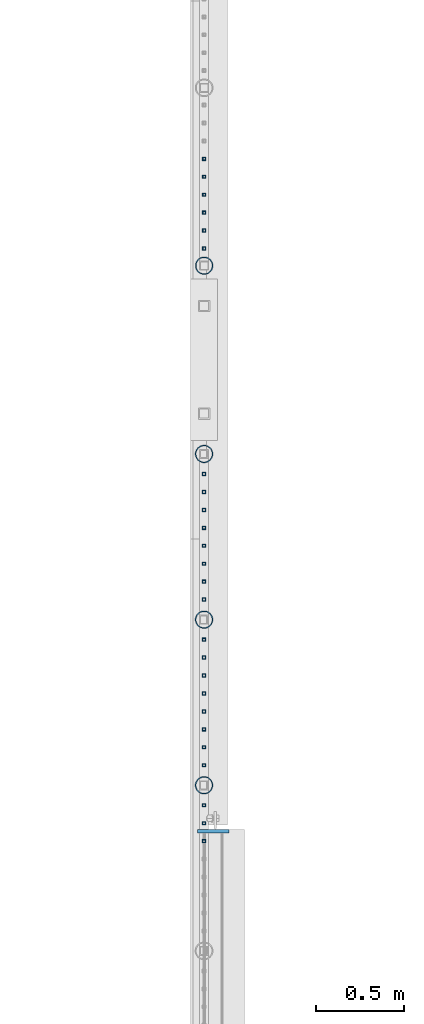
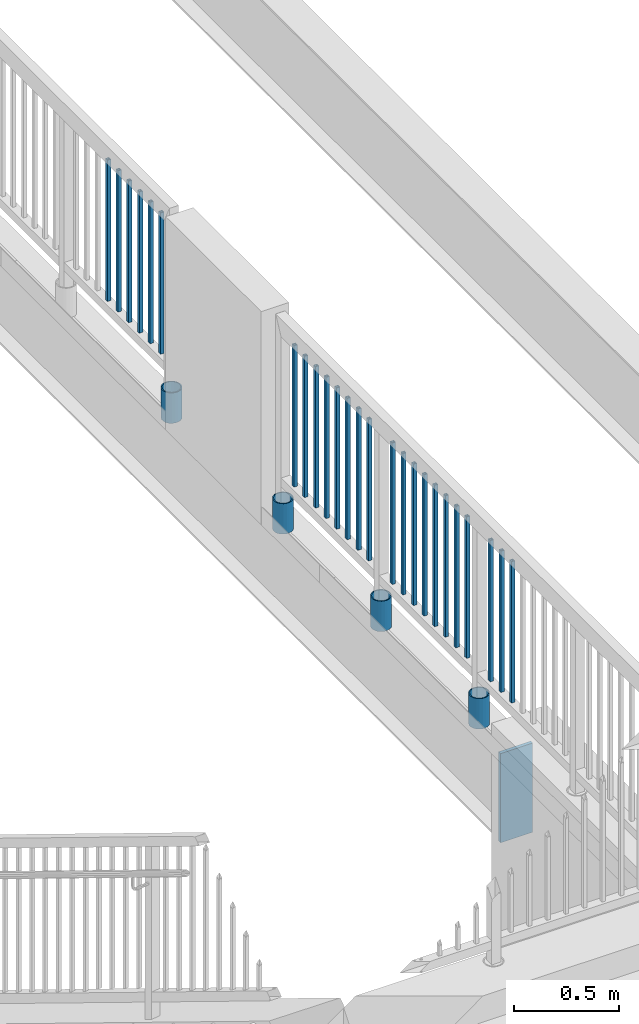
# One storey, part 227 of 975: 30 columns.
"""IFC2X3 building model written with IfcOpenShell, lengths in millimetres."""

from ifc_helpers import new_model, si_unit, frame, origin_with_axes, place, context, subcontext, project, spatial, faceted_brep, material, type_object, element, save


model = new_model("IFC2X3")

# Units and contexts
model_context = context("Model", 3, precision=1e-05, world=origin_with_axes())
body_context = subcontext(model_context, "Body", "Model", "MODEL_VIEW")
ifc_project = project(units=[si_unit("LENGTHUNIT", "METRE", prefix="MILLI"), si_unit("AREAUNIT", "SQUARE_METRE"), si_unit("VOLUMEUNIT", "CUBIC_METRE"), si_unit("MASSUNIT", "GRAM", prefix="KILO"), si_unit("TIMEUNIT", "SECOND"), si_unit("PLANEANGLEUNIT", "RADIAN"), si_unit("SOLIDANGLEUNIT", "STERADIAN"), si_unit("THERMODYNAMICTEMPERATUREUNIT", "DEGREE_CELSIUS"), si_unit("LUMINOUSINTENSITYUNIT", "LUMEN")], contexts=[model_context])

# Site, building, storey
site_placement = place(None, origin_with_axes())
site = spatial("IfcSite", under=ifc_project, at=site_placement, CompositionType="ELEMENT")
building_placement = place(site_placement, origin_with_axes())
building = spatial("IfcBuilding", under=site, at=building_placement, Name="Undefined", CompositionType="ELEMENT")
storey_placement = place(building_placement, origin_with_axes())
storey = spatial("IfcBuildingStorey", under=building, at=storey_placement, Name="Undefined", CompositionType="ELEMENT", Elevation=0.0)

# Columns
ifc_material_1 = material()
column_type_1 = type_object("IfcColumnType", Name="HSS3/4X3/4X.120_TUBES", PredefinedType="NOTDEFINED")
for number, where, z_axis, x_axis, name in (
    (1, (2092.26449887526, 26097.4441986005, 4254.49995104806), (0.0, 1.0, 0.0), (0.0, 0.0, 1.0), "PICKET"),
    (2, (2092.26449887526, 25995.8441986005, 4254.49995104806), (0.0, 1.0, 0.0), (0.0, 0.0, 1.0), "PICKET"),
    (3, (2092.26449887526, 25894.2441986005, 4254.49995104806), (0.0, 1.0, 0.0), (0.0, 0.0, 1.0), "PICKET"),
    (4, (2092.26449887526, 25792.6441986005, 4254.49995104806), (0.0, 1.0, 0.0), (0.0, 0.0, 1.0), "PICKET"),
    (5, (2092.26449887526, 25691.0441986005, 4254.49995104806), (0.0, 1.0, 0.0), (0.0, 0.0, 1.0), "PICKET"),
    (6, (2092.26449887526, 25589.4441986005, 4254.49995104806), (0.0, 1.0, 0.0), (0.0, 0.0, 1.0), "PICKET"),
    (7, (2091.96526343946, 24311.7655174883, 4254.50352503849), (0.0, 1.0, 0.0), (0.0, 0.0, 1.0), "PICKET"),
    (8, (2091.96526343946, 24210.1655174883, 4254.50352503849), (0.0, 1.0, 0.0), (0.0, 0.0, 1.0), "PICKET"),
    (9, (2091.96526343946, 24108.5655174883, 4254.50352503849), (0.0, 1.0, 0.0), (0.0, 0.0, 1.0), "PICKET"),
    (10, (2091.96526343946, 24006.9655174883, 4254.50352503849), (0.0, 1.0, 0.0), (0.0, 0.0, 1.0), "PICKET"),
    (11, (2091.96526343946, 23905.3655174883, 4254.50352503849), (0.0, 1.0, 0.0), (0.0, 0.0, 1.0), "PICKET"),
    (12, (2091.96526343946, 23803.7655174883, 4254.50352503849), (0.0, 1.0, 0.0), (0.0, 0.0, 1.0), "PICKET"),
    (13, (2091.96526343946, 23702.1655174883, 4254.50352503849), (0.0, 1.0, 0.0), (0.0, 0.0, 1.0), "PICKET"),
    (14, (2091.96526343946, 23600.5655174883, 4254.50352503849), (0.0, 1.0, 0.0), (0.0, 0.0, 1.0), "PICKET"),
    (15, (2091.77466910743, 23373.5544544983, 4254.50002056753), (0.0, 1.0, 0.0), (0.0, 0.0, 1.0), "PICKET"),
    (16, (2091.77466910743, 23271.9544544982, 4254.50002056753), (0.0, 1.0, 0.0), (0.0, 0.0, 1.0), "PICKET"),
    (17, (2091.77466910743, 23170.3544544983, 4254.50002056753), (0.0, 1.0, 0.0), (0.0, 0.0, 1.0), "PICKET"),
    (18, (2091.77466910743, 23068.7544544983, 4254.50002056753), (0.0, 1.0, 0.0), (0.0, 0.0, 1.0), "PICKET"),
    (19, (2091.77466910743, 22967.1544544982, 4254.50002056753), (0.0, 1.0, 0.0), (0.0, 0.0, 1.0), "PICKET"),
    (20, (2091.77466910743, 22865.5544544983, 4254.50002056753), (0.0, 1.0, 0.0), (0.0, 0.0, 1.0), "PICKET"),
    (21, (2091.77466910743, 22763.9544544982, 4254.50002056753), (0.0, 1.0, 0.0), (0.0, 0.0, 1.0), "PICKET"),
    (22, (2091.77466910743, 22662.3544544983, 4254.50002056753), (0.0, 1.0, 0.0), (0.0, 0.0, 1.0), "PICKET"),
    (23, (2091.7632059414, 22435.3416480171, 4254.50002056753), (0.0, 1.0, 0.0), (0.0, 0.0, 1.0), "PICKET"),
    (24, (2091.7632059414, 22333.7416480171, 4254.50002056753), (0.0, 1.0, 0.0), (0.0, 0.0, 1.0), "PICKET"),
    (25, (2091.7632059414, 22232.1416480171, 4254.50002056753), (0.0, 1.0, 0.0), (0.0, 0.0, 1.0), "PICKET"),
):
    element("IfcColumn", number, at=place(storey_placement, frame(where, z_axis=z_axis, x_axis=x_axis)), inside=storey, type_object=column_type_1, material=ifc_material_1, Name=name, ObjectType="HSS3/4X3/4X.120_TUBES", context=body_context, shape_type="Brep", body=[
        faceted_brep([(0.0, 6.34999999998763, -6.34999999998763), (0.0, -6.35000000000582, -6.34999999998763), (825.49997943247, -6.35000000000582, -6.34999999998763), (825.49997943247, 6.34999999998763, -6.34999999998763), (0.0, -6.34999999998763, 6.34999999998763), (825.49997943247, -6.34999999998763, 6.34999999998763), (0.0, 6.35000000000946, 6.34999999998763), (825.49997943247, 6.35000000000946, 6.34999999998763), (0.0, 9.52499999997963, -9.52499999997963), (0.0, 9.52500000000873, 9.5249999999869), (825.49997943247, 9.52500000000873, 9.5249999999869), (825.49997943247, 9.52499999997963, -9.52499999997963), (0.0, -9.52499999997963, 9.52499999998327), (825.49997943247, -9.52499999997963, 9.52499999998327), (0.0, -9.52500000000873, -9.5249999999869), (825.49997943247, -9.52500000000873, -9.5249999999869)], [[[0, 1, 2, 3]], [[1, 4, 5, 2]], [[4, 6, 7, 5]], [[6, 0, 3, 7]], [[8, 9, 10, 11]], [[9, 12, 13, 10]], [[12, 14, 15, 13]], [[14, 8, 11, 15]], [[13, 15, 11, 10], [5, 7, 3, 2]], [[14, 12, 9, 8], [6, 4, 1, 0]]]),
    ])
ifc_material_2 = material(Name="STEEL/A53")
column_type_2 = type_object("IfcColumnType", Name="PIPE3-1/2STD", PredefinedType="NOTDEFINED")
column_1_placement = place(storey_placement, frame((2091.86323353687, 22548.8491390868, 3937.0), z_axis=(-0.707106781186601, 0.707106781186494, 2.36468622460961e-14), x_axis=(0.0, 0.0, 1.0)))
element("IfcColumn", 26, at=column_1_placement, inside=storey, type_object=column_type_2, material=ifc_material_2, ObjectType="PIPE3-1/2STD", context=body_context, shape_type="Brep", body=[
    faceted_brep([(0.0, -45.0595999999932, 1.45519152283669e-11), (0.0, -42.8542262016344, 13.924182159768), (177.8, -42.8542262016344, 13.924182159768), (177.8, -45.0595999999932, 1.45519152283669e-11), (0.0, -36.45398215971, 26.4853683542424), (177.8, -36.45398215971, 26.4853683542424), (0.0, -26.4853683541623, 36.45398215979), (177.8, -26.4853683541623, 36.45398215979), (0.0, -13.9241821596988, 42.8542262017108), (177.8, -13.9241821596988, 42.8542262017108), (0.0, 3.63797880709171e-11, 45.0596000000514), (177.8, 3.63797880709171e-11, 45.0596000000514), (0.0, 13.9241821597716, 42.8542262017036), (177.8, 13.9241821597716, 42.8542262017036), (0.0, 26.4853683542242, 36.4539821597718), (177.8, 26.4853683542242, 36.4539821597718), (0.0, 36.4539821597537, 26.4853683542206), (177.8, 36.4539821597537, 26.4853683542206), (0.0, 42.8542262016563, 13.9241821597425), (177.8, 42.8542262016563, 13.9241821597425), (0.0, 45.0595999999932, -1.09139364212751e-11), (177.8, 45.0595999999932, -1.09139364212751e-11), (0.0, 42.8542262016344, -13.9241821597643), (177.8, 42.8542262016344, -13.9241821597643), (0.0, 36.45398215971, -26.4853683542387), (177.8, 36.45398215971, -26.4853683542387), (0.0, 26.4853683541623, -36.4539821597864), (177.8, 26.4853683541623, -36.4539821597864), (0.0, 13.9241821596988, -42.8542262017072), (177.8, 13.9241821596988, -42.8542262017072), (0.0, -3.63797880709171e-11, -45.0596000000478), (177.8, -3.63797880709171e-11, -45.0596000000478), (0.0, -13.9241821597716, -42.8542262016963), (177.8, -13.9241821597716, -42.8542262016963), (0.0, -26.4853683542242, -36.4539821597682), (177.8, -26.4853683542242, -36.4539821597682), (0.0, -36.4539821597537, -26.4853683542169), (177.8, -36.4539821597537, -26.4853683542169), (0.0, -42.8542262016563, -13.9241821597352), (177.8, -42.8542262016563, -13.9241821597352), (0.0, -50.799999999992, 1.81898940354586e-11), (0.0, -48.3136710278013, -15.6980633142484), (177.8, -48.3136710278013, -15.6980633142484), (177.8, -50.799999999992, 1.81898940354586e-11), (0.0, -41.0980633142644, -29.8594908164741), (177.8, -41.0980633142644, -29.8594908164741), (0.0, -29.859490816485, -41.0980633142826), (177.8, -29.859490816485, -41.0980633142826), (0.0, -15.6980633142848, -48.313671027845), (177.8, -15.6980633142848, -48.313671027845), (0.0, -4.36557456851006e-11, -50.8000000000575), (177.8, -4.36557456851006e-11, -50.8000000000575), (0.0, 15.6980633142011, -48.3136710278523), (177.8, 15.6980633142011, -48.3136710278523), (0.0, 29.8594908164159, -41.0980633143045), (177.8, 29.8594908164159, -41.0980633143045), (0.0, 41.0980633142135, -29.8594908165032), (177.8, 41.0980633142135, -29.8594908165032), (0.0, 48.3136710277722, -15.6980633142775), (177.8, 48.3136710277722, -15.6980633142775), (0.0, 50.799999999992, -1.45519152283669e-11), (177.8, 50.799999999992, -1.45519152283669e-11), (0.0, 48.313671027794, 15.6980633142521), (177.8, 48.313671027794, 15.6980633142521), (0.0, 41.0980633142644, 29.8594908164814), (177.8, 41.0980633142644, 29.8594908164814), (0.0, 29.859490816485, 41.0980633142863), (177.8, 29.859490816485, 41.0980633142863), (0.0, 15.6980633142848, 48.3136710278486), (177.8, 15.6980633142848, 48.3136710278486), (0.0, 4.00177668780088e-11, 50.8000000000611), (177.8, 4.00177668780088e-11, 50.8000000000611), (0.0, -15.6980633142011, 48.3136710278559), (177.8, -15.6980633142011, 48.3136710278559), (0.0, -29.8594908164159, 41.0980633143081), (177.8, -29.8594908164159, 41.0980633143081), (0.0, -41.0980633142171, 29.8594908165069), (177.8, -41.0980633142171, 29.8594908165069), (0.0, -48.3136710277722, 15.6980633142812), (177.8, -48.3136710277722, 15.6980633142812)], [[[0, 1, 2, 3]], [[1, 4, 5, 2]], [[4, 6, 7, 5]], [[6, 8, 9, 7]], [[8, 10, 11, 9]], [[10, 12, 13, 11]], [[12, 14, 15, 13]], [[14, 16, 17, 15]], [[16, 18, 19, 17]], [[18, 20, 21, 19]], [[20, 22, 23, 21]], [[22, 24, 25, 23]], [[24, 26, 27, 25]], [[26, 28, 29, 27]], [[28, 30, 31, 29]], [[30, 32, 33, 31]], [[32, 34, 35, 33]], [[34, 36, 37, 35]], [[36, 38, 39, 37]], [[38, 0, 3, 39]], [[40, 41, 42, 43]], [[41, 44, 45, 42]], [[44, 46, 47, 45]], [[46, 48, 49, 47]], [[48, 50, 51, 49]], [[50, 52, 53, 51]], [[52, 54, 55, 53]], [[54, 56, 57, 55]], [[56, 58, 59, 57]], [[58, 60, 61, 59]], [[60, 62, 63, 61]], [[62, 64, 65, 63]], [[64, 66, 67, 65]], [[66, 68, 69, 67]], [[68, 70, 71, 69]], [[70, 72, 73, 71]], [[72, 74, 75, 73]], [[74, 76, 77, 75]], [[76, 78, 79, 77]], [[78, 40, 43, 79]], [[45, 47, 49, 51, 53, 55, 57, 59, 61, 63, 65, 67, 69, 71, 73, 75, 77, 79, 43, 42], [5, 7, 9, 11, 13, 15, 17, 19, 21, 23, 25, 27, 29, 31, 33, 35, 37, 39, 3, 2]], [[78, 76, 74, 72, 70, 68, 66, 64, 62, 60, 58, 56, 54, 52, 50, 48, 46, 44, 41, 40], [38, 36, 34, 32, 30, 28, 26, 24, 22, 20, 18, 16, 14, 12, 10, 8, 6, 4, 1, 0]]]),
])
column_2_placement = place(storey_placement, frame((2091.98883508309, 23487.0582877675, 3937.00001429355), z_axis=(-0.707106781186601, 0.707106781186494, 2.36468622460961e-14), x_axis=(0.0, 0.0, 1.0)))
element("IfcColumn", 27, at=column_2_placement, inside=storey, type_object=column_type_2, material=ifc_material_2, ObjectType="PIPE3-1/2STD", context=body_context, shape_type="Brep", body=[
    faceted_brep([(0.0, -45.0595999999932, 1.45519152283669e-11), (0.0, -42.8542262016344, 13.924182159768), (177.8, -42.8542262016344, 13.924182159768), (177.8, -45.0595999999932, 1.45519152283669e-11), (0.0, -36.45398215971, 26.4853683542424), (177.8, -36.45398215971, 26.4853683542424), (0.0, -26.4853683541623, 36.45398215979), (177.8, -26.4853683541623, 36.45398215979), (0.0, -13.9241821596988, 42.8542262017108), (177.8, -13.9241821596988, 42.8542262017108), (0.0, 3.63797880709171e-11, 45.0596000000514), (177.8, 3.63797880709171e-11, 45.0596000000514), (0.0, 13.9241821597716, 42.8542262017036), (177.8, 13.9241821597716, 42.8542262017036), (0.0, 26.4853683542242, 36.4539821597718), (177.8, 26.4853683542242, 36.4539821597718), (0.0, 36.4539821597537, 26.4853683542206), (177.8, 36.4539821597537, 26.4853683542206), (0.0, 42.8542262016563, 13.9241821597425), (177.8, 42.8542262016563, 13.9241821597425), (0.0, 45.0595999999932, -1.09139364212751e-11), (177.8, 45.0595999999932, -1.09139364212751e-11), (0.0, 42.8542262016344, -13.9241821597643), (177.8, 42.8542262016344, -13.9241821597643), (0.0, 36.45398215971, -26.4853683542387), (177.8, 36.45398215971, -26.4853683542387), (0.0, 26.4853683541623, -36.4539821597864), (177.8, 26.4853683541623, -36.4539821597864), (0.0, 13.9241821596988, -42.8542262017072), (177.8, 13.9241821596988, -42.8542262017072), (0.0, -3.63797880709171e-11, -45.0596000000478), (177.8, -3.63797880709171e-11, -45.0596000000478), (0.0, -13.9241821597716, -42.8542262016963), (177.8, -13.9241821597716, -42.8542262016963), (0.0, -26.4853683542242, -36.4539821597682), (177.8, -26.4853683542242, -36.4539821597682), (0.0, -36.4539821597537, -26.4853683542169), (177.8, -36.4539821597537, -26.4853683542169), (0.0, -42.8542262016563, -13.9241821597352), (177.8, -42.8542262016563, -13.9241821597352), (0.0, -50.799999999992, 1.81898940354586e-11), (0.0, -48.3136710278013, -15.6980633142484), (177.8, -48.3136710278013, -15.6980633142484), (177.8, -50.799999999992, 1.81898940354586e-11), (0.0, -41.0980633142644, -29.8594908164741), (177.8, -41.0980633142644, -29.8594908164741), (0.0, -29.859490816485, -41.0980633142826), (177.8, -29.859490816485, -41.0980633142826), (0.0, -15.6980633142848, -48.313671027845), (177.8, -15.6980633142848, -48.313671027845), (0.0, -4.36557456851006e-11, -50.8000000000575), (177.8, -4.36557456851006e-11, -50.8000000000575), (0.0, 15.6980633142011, -48.3136710278523), (177.8, 15.6980633142011, -48.3136710278523), (0.0, 29.8594908164159, -41.0980633143045), (177.8, 29.8594908164159, -41.0980633143045), (0.0, 41.0980633142135, -29.8594908165032), (177.8, 41.0980633142135, -29.8594908165032), (0.0, 48.3136710277722, -15.6980633142775), (177.8, 48.3136710277722, -15.6980633142775), (0.0, 50.799999999992, -1.45519152283669e-11), (177.8, 50.799999999992, -1.45519152283669e-11), (0.0, 48.313671027794, 15.6980633142521), (177.8, 48.313671027794, 15.6980633142521), (0.0, 41.0980633142644, 29.8594908164814), (177.8, 41.0980633142644, 29.8594908164814), (0.0, 29.859490816485, 41.0980633142863), (177.8, 29.859490816485, 41.0980633142863), (0.0, 15.6980633142848, 48.3136710278486), (177.8, 15.6980633142848, 48.3136710278486), (0.0, 4.00177668780088e-11, 50.8000000000611), (177.8, 4.00177668780088e-11, 50.8000000000611), (0.0, -15.6980633142011, 48.3136710278559), (177.8, -15.6980633142011, 48.3136710278559), (0.0, -29.8594908164159, 41.0980633143081), (177.8, -29.8594908164159, 41.0980633143081), (0.0, -41.0980633142171, 29.8594908165069), (177.8, -41.0980633142171, 29.8594908165069), (0.0, -48.3136710277722, 15.6980633142812), (177.8, -48.3136710277722, 15.6980633142812)], [[[0, 1, 2, 3]], [[1, 4, 5, 2]], [[4, 6, 7, 5]], [[6, 8, 9, 7]], [[8, 10, 11, 9]], [[10, 12, 13, 11]], [[12, 14, 15, 13]], [[14, 16, 17, 15]], [[16, 18, 19, 17]], [[18, 20, 21, 19]], [[20, 22, 23, 21]], [[22, 24, 25, 23]], [[24, 26, 27, 25]], [[26, 28, 29, 27]], [[28, 30, 31, 29]], [[30, 32, 33, 31]], [[32, 34, 35, 33]], [[34, 36, 37, 35]], [[36, 38, 39, 37]], [[38, 0, 3, 39]], [[40, 41, 42, 43]], [[41, 44, 45, 42]], [[44, 46, 47, 45]], [[46, 48, 49, 47]], [[48, 50, 51, 49]], [[50, 52, 53, 51]], [[52, 54, 55, 53]], [[54, 56, 57, 55]], [[56, 58, 59, 57]], [[58, 60, 61, 59]], [[60, 62, 63, 61]], [[62, 64, 65, 63]], [[64, 66, 67, 65]], [[66, 68, 69, 67]], [[68, 70, 71, 69]], [[70, 72, 73, 71]], [[72, 74, 75, 73]], [[74, 76, 77, 75]], [[76, 78, 79, 77]], [[78, 40, 43, 79]], [[45, 47, 49, 51, 53, 55, 57, 59, 61, 63, 65, 67, 69, 71, 73, 75, 77, 79, 43, 42], [5, 7, 9, 11, 13, 15, 17, 19, 21, 23, 25, 27, 29, 31, 33, 35, 37, 39, 3, 2]], [[78, 76, 74, 72, 70, 68, 66, 64, 62, 60, 58, 56, 54, 52, 50, 48, 46, 44, 41, 40], [38, 36, 34, 32, 30, 28, 26, 24, 22, 20, 18, 16, 14, 12, 10, 8, 6, 4, 1, 0]]]),
])
column_3_placement = place(storey_placement, frame((2092.11049849854, 24425.5733523964, 3937.0), z_axis=(-0.707106781186601, 0.707106781186494, 2.36468622460961e-14), x_axis=(0.0, 0.0, 1.0)))
element("IfcColumn", 28, at=column_3_placement, inside=storey, type_object=column_type_2, material=ifc_material_2, ObjectType="PIPE3-1/2STD", context=body_context, shape_type="Brep", body=[
    faceted_brep([(0.0, -45.0595999999932, 1.45519152283669e-11), (0.0, -42.8542262016344, 13.924182159768), (177.8, -42.8542262016344, 13.924182159768), (177.8, -45.0595999999932, 1.45519152283669e-11), (0.0, -36.45398215971, 26.4853683542424), (177.8, -36.45398215971, 26.4853683542424), (0.0, -26.4853683541623, 36.45398215979), (177.8, -26.4853683541623, 36.45398215979), (0.0, -13.9241821596988, 42.8542262017108), (177.8, -13.9241821596988, 42.8542262017108), (0.0, 3.63797880709171e-11, 45.0596000000514), (177.8, 3.63797880709171e-11, 45.0596000000514), (0.0, 13.9241821597716, 42.8542262017036), (177.8, 13.9241821597716, 42.8542262017036), (0.0, 26.4853683542242, 36.4539821597718), (177.8, 26.4853683542242, 36.4539821597718), (0.0, 36.4539821597537, 26.4853683542206), (177.8, 36.4539821597537, 26.4853683542206), (0.0, 42.8542262016563, 13.9241821597425), (177.8, 42.8542262016563, 13.9241821597425), (0.0, 45.0595999999932, -1.09139364212751e-11), (177.8, 45.0595999999932, -1.09139364212751e-11), (0.0, 42.8542262016344, -13.9241821597643), (177.8, 42.8542262016344, -13.9241821597643), (0.0, 36.45398215971, -26.4853683542387), (177.8, 36.45398215971, -26.4853683542387), (0.0, 26.4853683541623, -36.4539821597864), (177.8, 26.4853683541623, -36.4539821597864), (0.0, 13.9241821596988, -42.8542262017072), (177.8, 13.9241821596988, -42.8542262017072), (0.0, -3.63797880709171e-11, -45.0596000000478), (177.8, -3.63797880709171e-11, -45.0596000000478), (0.0, -13.9241821597716, -42.8542262016963), (177.8, -13.9241821597716, -42.8542262016963), (0.0, -26.4853683542242, -36.4539821597682), (177.8, -26.4853683542242, -36.4539821597682), (0.0, -36.4539821597537, -26.4853683542169), (177.8, -36.4539821597537, -26.4853683542169), (0.0, -42.8542262016563, -13.9241821597352), (177.8, -42.8542262016563, -13.9241821597352), (0.0, -50.799999999992, 1.81898940354586e-11), (0.0, -48.3136710278013, -15.6980633142484), (177.8, -48.3136710278013, -15.6980633142484), (177.8, -50.799999999992, 1.81898940354586e-11), (0.0, -41.0980633142644, -29.8594908164741), (177.8, -41.0980633142644, -29.8594908164741), (0.0, -29.859490816485, -41.0980633142826), (177.8, -29.859490816485, -41.0980633142826), (0.0, -15.6980633142848, -48.313671027845), (177.8, -15.6980633142848, -48.313671027845), (0.0, -4.36557456851006e-11, -50.8000000000575), (177.8, -4.36557456851006e-11, -50.8000000000575), (0.0, 15.6980633142011, -48.3136710278523), (177.8, 15.6980633142011, -48.3136710278523), (0.0, 29.8594908164159, -41.0980633143045), (177.8, 29.8594908164159, -41.0980633143045), (0.0, 41.0980633142135, -29.8594908165032), (177.8, 41.0980633142135, -29.8594908165032), (0.0, 48.3136710277722, -15.6980633142775), (177.8, 48.3136710277722, -15.6980633142775), (0.0, 50.799999999992, -1.45519152283669e-11), (177.8, 50.799999999992, -1.45519152283669e-11), (0.0, 48.313671027794, 15.6980633142521), (177.8, 48.313671027794, 15.6980633142521), (0.0, 41.0980633142644, 29.8594908164814), (177.8, 41.0980633142644, 29.8594908164814), (0.0, 29.859490816485, 41.0980633142863), (177.8, 29.859490816485, 41.0980633142863), (0.0, 15.6980633142848, 48.3136710278486), (177.8, 15.6980633142848, 48.3136710278486), (0.0, 4.00177668780088e-11, 50.8000000000611), (177.8, 4.00177668780088e-11, 50.8000000000611), (0.0, -15.6980633142011, 48.3136710278559), (177.8, -15.6980633142011, 48.3136710278559), (0.0, -29.8594908164159, 41.0980633143081), (177.8, -29.8594908164159, 41.0980633143081), (0.0, -41.0980633142171, 29.8594908165069), (177.8, -41.0980633142171, 29.8594908165069), (0.0, -48.3136710277722, 15.6980633142812), (177.8, -48.3136710277722, 15.6980633142812)], [[[0, 1, 2, 3]], [[1, 4, 5, 2]], [[4, 6, 7, 5]], [[6, 8, 9, 7]], [[8, 10, 11, 9]], [[10, 12, 13, 11]], [[12, 14, 15, 13]], [[14, 16, 17, 15]], [[16, 18, 19, 17]], [[18, 20, 21, 19]], [[20, 22, 23, 21]], [[22, 24, 25, 23]], [[24, 26, 27, 25]], [[26, 28, 29, 27]], [[28, 30, 31, 29]], [[30, 32, 33, 31]], [[32, 34, 35, 33]], [[34, 36, 37, 35]], [[36, 38, 39, 37]], [[38, 0, 3, 39]], [[40, 41, 42, 43]], [[41, 44, 45, 42]], [[44, 46, 47, 45]], [[46, 48, 49, 47]], [[48, 50, 51, 49]], [[50, 52, 53, 51]], [[52, 54, 55, 53]], [[54, 56, 57, 55]], [[56, 58, 59, 57]], [[58, 60, 61, 59]], [[60, 62, 63, 61]], [[62, 64, 65, 63]], [[64, 66, 67, 65]], [[66, 68, 69, 67]], [[68, 70, 71, 69]], [[70, 72, 73, 71]], [[72, 74, 75, 73]], [[74, 76, 77, 75]], [[76, 78, 79, 77]], [[78, 40, 43, 79]], [[45, 47, 49, 51, 53, 55, 57, 59, 61, 63, 65, 67, 69, 71, 73, 75, 77, 79, 43, 42], [5, 7, 9, 11, 13, 15, 17, 19, 21, 23, 25, 27, 29, 31, 33, 35, 37, 39, 3, 2]], [[78, 76, 74, 72, 70, 68, 66, 64, 62, 60, 58, 56, 54, 52, 50, 48, 46, 44, 41, 40], [38, 36, 34, 32, 30, 28, 26, 24, 22, 20, 18, 16, 14, 12, 10, 8, 6, 4, 1, 0]]]),
])
column_4_placement = place(storey_placement, frame((2092.2586399658, 25492.078072198, 3937.0), z_axis=(-0.707106781186601, 0.707106781186494, 2.36468622460961e-14), x_axis=(0.0, 0.0, 1.0)))
element("IfcColumn", 29, at=column_4_placement, inside=storey, type_object=column_type_2, material=ifc_material_2, ObjectType="PIPE3-1/2STD", context=body_context, shape_type="Brep", body=[
    faceted_brep([(0.0, -45.0595999999932, 1.45519152283669e-11), (0.0, -42.8542262016344, 13.924182159768), (177.8, -42.8542262016344, 13.924182159768), (177.8, -45.0595999999932, 1.45519152283669e-11), (0.0, -36.45398215971, 26.4853683542424), (177.8, -36.45398215971, 26.4853683542424), (0.0, -26.4853683541623, 36.45398215979), (177.8, -26.4853683541623, 36.45398215979), (0.0, -13.9241821596988, 42.8542262017108), (177.8, -13.9241821596988, 42.8542262017108), (0.0, 3.63797880709171e-11, 45.0596000000514), (177.8, 3.63797880709171e-11, 45.0596000000514), (0.0, 13.9241821597716, 42.8542262017036), (177.8, 13.9241821597716, 42.8542262017036), (0.0, 26.4853683542242, 36.4539821597718), (177.8, 26.4853683542242, 36.4539821597718), (0.0, 36.4539821597537, 26.4853683542206), (177.8, 36.4539821597537, 26.4853683542206), (0.0, 42.8542262016563, 13.9241821597425), (177.8, 42.8542262016563, 13.9241821597425), (0.0, 45.0595999999932, -1.09139364212751e-11), (177.8, 45.0595999999932, -1.09139364212751e-11), (0.0, 42.8542262016344, -13.9241821597643), (177.8, 42.8542262016344, -13.9241821597643), (0.0, 36.45398215971, -26.4853683542387), (177.8, 36.45398215971, -26.4853683542387), (0.0, 26.4853683541623, -36.4539821597864), (177.8, 26.4853683541623, -36.4539821597864), (0.0, 13.9241821596988, -42.8542262017072), (177.8, 13.9241821596988, -42.8542262017072), (0.0, -3.63797880709171e-11, -45.0596000000478), (177.8, -3.63797880709171e-11, -45.0596000000478), (0.0, -13.9241821597716, -42.8542262016963), (177.8, -13.9241821597716, -42.8542262016963), (0.0, -26.4853683542242, -36.4539821597682), (177.8, -26.4853683542242, -36.4539821597682), (0.0, -36.4539821597537, -26.4853683542169), (177.8, -36.4539821597537, -26.4853683542169), (0.0, -42.8542262016563, -13.9241821597352), (177.8, -42.8542262016563, -13.9241821597352), (0.0, -50.799999999992, 1.81898940354586e-11), (0.0, -48.3136710278013, -15.6980633142484), (177.8, -48.3136710278013, -15.6980633142484), (177.8, -50.799999999992, 1.81898940354586e-11), (0.0, -41.0980633142644, -29.8594908164741), (177.8, -41.0980633142644, -29.8594908164741), (0.0, -29.859490816485, -41.0980633142826), (177.8, -29.859490816485, -41.0980633142826), (0.0, -15.6980633142848, -48.313671027845), (177.8, -15.6980633142848, -48.313671027845), (0.0, -4.36557456851006e-11, -50.8000000000575), (177.8, -4.36557456851006e-11, -50.8000000000575), (0.0, 15.6980633142011, -48.3136710278523), (177.8, 15.6980633142011, -48.3136710278523), (0.0, 29.8594908164159, -41.0980633143045), (177.8, 29.8594908164159, -41.0980633143045), (0.0, 41.0980633142135, -29.8594908165032), (177.8, 41.0980633142135, -29.8594908165032), (0.0, 48.3136710277722, -15.6980633142775), (177.8, 48.3136710277722, -15.6980633142775), (0.0, 50.799999999992, -1.45519152283669e-11), (177.8, 50.799999999992, -1.45519152283669e-11), (0.0, 48.313671027794, 15.6980633142521), (177.8, 48.313671027794, 15.6980633142521), (0.0, 41.0980633142644, 29.8594908164814), (177.8, 41.0980633142644, 29.8594908164814), (0.0, 29.859490816485, 41.0980633142863), (177.8, 29.859490816485, 41.0980633142863), (0.0, 15.6980633142848, 48.3136710278486), (177.8, 15.6980633142848, 48.3136710278486), (0.0, 4.00177668780088e-11, 50.8000000000611), (177.8, 4.00177668780088e-11, 50.8000000000611), (0.0, -15.6980633142011, 48.3136710278559), (177.8, -15.6980633142011, 48.3136710278559), (0.0, -29.8594908164159, 41.0980633143081), (177.8, -29.8594908164159, 41.0980633143081), (0.0, -41.0980633142171, 29.8594908165069), (177.8, -41.0980633142171, 29.8594908165069), (0.0, -48.3136710277722, 15.6980633142812), (177.8, -48.3136710277722, 15.6980633142812)], [[[0, 1, 2, 3]], [[1, 4, 5, 2]], [[4, 6, 7, 5]], [[6, 8, 9, 7]], [[8, 10, 11, 9]], [[10, 12, 13, 11]], [[12, 14, 15, 13]], [[14, 16, 17, 15]], [[16, 18, 19, 17]], [[18, 20, 21, 19]], [[20, 22, 23, 21]], [[22, 24, 25, 23]], [[24, 26, 27, 25]], [[26, 28, 29, 27]], [[28, 30, 31, 29]], [[30, 32, 33, 31]], [[32, 34, 35, 33]], [[34, 36, 37, 35]], [[36, 38, 39, 37]], [[38, 0, 3, 39]], [[40, 41, 42, 43]], [[41, 44, 45, 42]], [[44, 46, 47, 45]], [[46, 48, 49, 47]], [[48, 50, 51, 49]], [[50, 52, 53, 51]], [[52, 54, 55, 53]], [[54, 56, 57, 55]], [[56, 58, 59, 57]], [[58, 60, 61, 59]], [[60, 62, 63, 61]], [[62, 64, 65, 63]], [[64, 66, 67, 65]], [[66, 68, 69, 67]], [[68, 70, 71, 69]], [[70, 72, 73, 71]], [[72, 74, 75, 73]], [[74, 76, 77, 75]], [[76, 78, 79, 77]], [[78, 40, 43, 79]], [[45, 47, 49, 51, 53, 55, 57, 59, 61, 63, 65, 67, 69, 71, 73, 75, 77, 79, 43, 42], [5, 7, 9, 11, 13, 15, 17, 19, 21, 23, 25, 27, 29, 31, 33, 35, 37, 39, 3, 2]], [[78, 76, 74, 72, 70, 68, 66, 64, 62, 60, 58, 56, 54, 52, 50, 48, 46, 44, 41, 40], [38, 36, 34, 32, 30, 28, 26, 24, 22, 20, 18, 16, 14, 12, 10, 8, 6, 4, 1, 0]]]),
])
ifc_material_3 = material(Name="STEEL/A36")
column_type_3 = type_object("IfcColumnType", PredefinedType="NOTDEFINED")
column_5_placement = place(storey_placement, frame((2143.125, 22288.5, 3414.7125), z_axis=(1.0, 0.0, 0.0), x_axis=(0.0, 0.0, 1.0)))
element("IfcColumn", 30, at=column_5_placement, inside=storey, type_object=column_type_3, material=ifc_material_3, Name="PLATE", context=body_context, shape_type="Brep", body=[
    faceted_brep([(0.0, 9.52499999999964, -88.9000000000015), (0.0, 9.52499999999964, 88.9000000000015), (520.699964490948, 9.52499999999964, 88.9000000000015), (520.699964490948, 9.52499999999964, -88.9000000000015), (0.0, -9.52499999999964, 88.9000000000015), (520.699964490948, -9.52499999999964, 88.9000000000015), (0.0, -9.52499999999964, -88.9000000000015), (520.699964490948, -9.52499999999964, -88.9000000000015)], [[[0, 1, 2, 3]], [[1, 4, 5, 2]], [[4, 6, 7, 5]], [[6, 0, 3, 7]], [[5, 7, 3, 2]], [[6, 4, 1, 0]]]),
])

save(model, "model.ifc")
